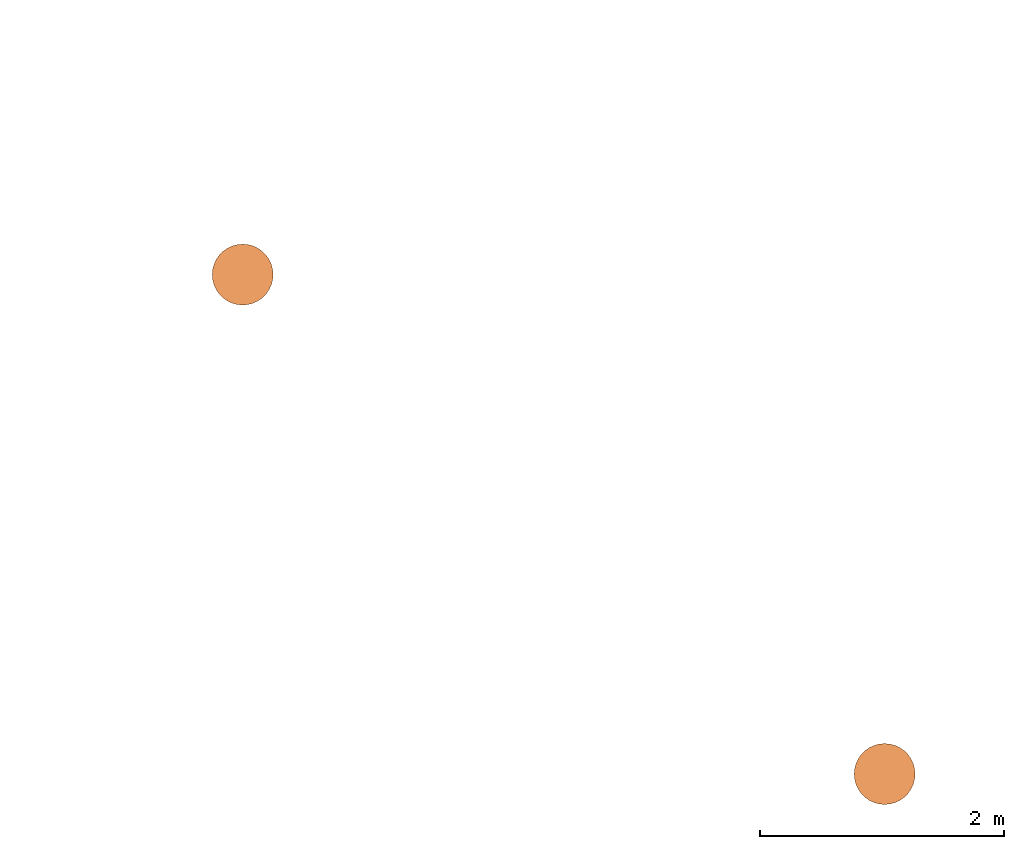
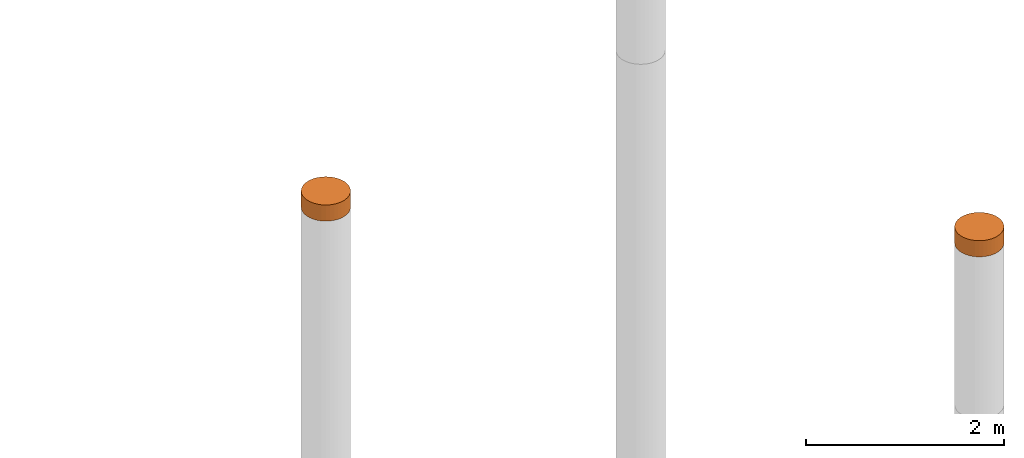
# One storey, part 7 of 8: 2 proxies.
"""IFC4 building model written with IfcOpenShell, lengths in metres."""

import ifcopenshell
import ifcopenshell.guid

model = None  # the IFC model being written
_history = None  # IfcOwnerHistory: only IFC2X3 demands one
_inside = {}  # id of a spatial element -> (the spatial element, [elements in it])
_under = {}  # id of a project, library or spatial element -> (it, [spatial elements below it])
_declared = {}  # id of a project -> (the project, [libraries it declares])
_typed = {}  # id of a type object -> (the type object, [elements of that type])
_made_of = {}  # id of a material, layer set ... -> (it, [elements and type objects made of it])


def new_model(schema):
    """Start an empty IFC model of exactly this schema.

    Asked for "IFC4X3", IfcOpenShell would pick the latest addendum, in which some entities
    have other attributes; the version numbers below select the first issue.
    IFC2X3 requires an IfcOwnerHistory on every rooted entity: one is made here for all.
    """
    global model, _history
    if schema == "IFC4X3":
        model = ifcopenshell.file(schema_version=(4, 3, 0, 0))
    else:
        model = ifcopenshell.file(schema=schema)
    _inside.clear()
    _under.clear()
    _declared.clear()
    _typed.clear()
    _made_of.clear()
    _history = None
    if model.schema == "IFC2X3":
        org = make("IfcOrganization", Name="unknown")
        user = make(
            "IfcPersonAndOrganization",
            ThePerson=make("IfcPerson", FamilyName="unknown"),
            TheOrganization=org,
        )
        app = make(
            "IfcApplication",
            ApplicationDeveloper=org,
            Version="unknown",
            ApplicationFullName="unknown",
            ApplicationIdentifier="unknown",
        )
        _history = make(
            "IfcOwnerHistory",
            OwningUser=user,
            OwningApplication=app,
            ChangeAction="ADDED",
            CreationDate=0,
        )
    return model


def make(cls, **values):
    """One entity of the class cls with the attributes given. An attribute that is None is left unset."""
    return model.create_entity(
        cls, **{name: value for name, value in values.items() if value is not None}
    )


def entity(cls, *values):
    """Any entity or typed value of the class cls, its attributes in the order of the schema. None: left unset."""
    e = model.create_entity(cls)
    for i, value in enumerate(values):
        if value is not None:
            e[i] = value
    return e


def rooted(cls, **values):
    """An entity with a GlobalId (a new one), such as an element, a storey or a relation."""
    return make(cls, GlobalId=ifcopenshell.guid.new(), OwnerHistory=_history, **values)


def si_unit(unit_type, name, prefix=None):
    """IfcSIUnit, for example si_unit("LENGTHUNIT", "METRE", prefix="MILLI")."""
    return make("IfcSIUnit", UnitType=unit_type, Prefix=prefix, Name=name)


def converted_unit(unit_type, name, factor, base, dimensions=None, offset=None):
    """IfcConversionBasedUnit, such as the inch: factor (a typed value) times the base unit."""
    return make(
        "IfcConversionBasedUnit"
        if offset is None
        else "IfcConversionBasedUnitWithOffset",
        ConversionOffset=offset,
        Dimensions=None
        if dimensions is None
        else entity("IfcDimensionalExponents", *dimensions),
        UnitType=unit_type,
        Name=name,
        ConversionFactor=make(
            "IfcMeasureWithUnit", ValueComponent=factor, UnitComponent=base
        ),
    )


def assignment(units):
    """IfcUnitAssignment: the units of a project."""
    return None if units is None else make("IfcUnitAssignment", Units=units)


def point(xyz):
    """IfcCartesianPoint."""
    return None if xyz is None else make("IfcCartesianPoint", Coordinates=xyz)


def direction(xyz):
    """IfcDirection."""
    return None if xyz is None else make("IfcDirection", DirectionRatios=xyz)


def frame(location, z_axis=None, x_axis=None):
    """IfcAxis2Placement3D, a coordinate frame: its origin and axes. An axis left out is left unset."""
    return make(
        "IfcAxis2Placement3D",
        Location=point(location),
        Axis=direction(z_axis),
        RefDirection=direction(x_axis),
    )


def origin():
    """The frame at (0, 0, 0) with its axes left unset."""
    return frame((0.0, 0.0, 0.0))


def place(relative_to, where):
    """IfcLocalPlacement: puts the frame where relative to a parent placement (None: the world)."""
    return make(
        "IfcLocalPlacement", PlacementRelTo=relative_to, RelativePlacement=where
    )


def context(
    kind, dimensions, precision=None, world=None, true_north=None, identifier=None
):
    """IfcGeometricRepresentationContext, for example the 3D "Model" context."""
    return make(
        "IfcGeometricRepresentationContext",
        ContextIdentifier=identifier,
        ContextType=kind,
        CoordinateSpaceDimension=dimensions,
        Precision=precision,
        WorldCoordinateSystem=world,
        TrueNorth=true_north,
    )


def subcontext(parent, identifier, kind, view, scale=None):
    """IfcGeometricRepresentationSubContext, for example "Body" below "Model"."""
    return make(
        "IfcGeometricRepresentationSubContext",
        ContextIdentifier=identifier,
        ContextType=kind,
        ParentContext=parent,
        TargetScale=scale,
        TargetView=view,
    )


def project(units=None, contexts=None):
    """IfcProject with its units and contexts."""
    return rooted(
        "IfcProject",
        Name="project",
        RepresentationContexts=contexts,
        UnitsInContext=assignment(units),
    )


def spatial(cls, under=None, at=None, **own):
    """A site, building, storey or space (cls), placed at a placement, below another one or the project."""
    s = rooted(cls, ObjectPlacement=at, **own)
    if under is not None:
        _under.setdefault(under.id(), (under, []))[1].append(s)
    return s


def faces_of(points, faces, orient=None, outer=None):
    """IfcFace entities. A face is a list of loops; a loop is a list of indices into points, from 0.

    orient and outer hold one flag for each loop. By default every Orientation is true, the
    first loop of a face is its IfcFaceOuterBound and the others are IfcFaceBound.
    """
    made = []
    for i, loops in enumerate(faces):
        bounds = []
        for j, loop in enumerate(loops):
            is_outer = j == 0 if outer is None else outer[i][j]
            bounds.append(
                make(
                    "IfcFaceOuterBound" if is_outer else "IfcFaceBound",
                    Bound=make("IfcPolyLoop", Polygon=[points[k] for k in loop]),
                    Orientation=True if orient is None else orient[i][j],
                )
            )
        made.append(make("IfcFace", Bounds=bounds))
    return made


def faceted_brep(points, faces, orient=None, outer=None, voids=None):
    """IfcFacetedBrep: a solid bounded by flat faces; with voids (closed shells), ...WithVoids."""
    shared = [point(p) for p in points]
    hull = make("IfcClosedShell", CfsFaces=faces_of(shared, faces, orient, outer))
    if voids is None:
        return make("IfcFacetedBrep", Outer=hull)
    return make(
        "IfcFacetedBrepWithVoids",
        Outer=hull,
        Voids=[
            make(cls, CfsFaces=faces_of(shared, fs, o, b)) for cls, fs, o, b in voids
        ],
    )


def shape(context_of_items, identifier, shape_type, items):
    """IfcShapeRepresentation: the items that make up one representation, for example the "Body"."""
    return make(
        "IfcShapeRepresentation",
        ContextOfItems=context_of_items,
        RepresentationIdentifier=identifier,
        RepresentationType=shape_type,
        Items=items,
    )


def material(Name=None, Category=None):
    """IfcMaterial."""
    return make("IfcMaterial", Name=Name, Category=Category)


def made_of(thing, what):
    """Note that an element or type object is made of a material, layer set ...; save() writes the relation."""
    if what is not None:
        _made_of.setdefault(what.id(), (what, []))[1].append(thing)
    return thing


def element(
    cls,
    number,
    at=None,
    inside=None,
    cuts=None,
    type_object=None,
    material=None,
    context=None,
    identifier="Body",
    shape_type=None,
    held_by="IfcProductDefinitionShape",
    body=None,
    shapes=None,
    **own,
):
    """One element of the class cls, such as IfcWall. Its Tag is "e" and its number.

    at: its placement. inside: the storey or other place that contains it. cuts: it is an
    opening in that element (IfcRelVoidsElement). A single representation is given by context,
    identifier, shape_type and body (its items); several are given by shapes. held_by: the class
    of the entity that holds the representations. save() writes the other relations.
    """
    e = rooted(cls, Tag="e%d" % number, ObjectPlacement=at, **own)
    if body is not None:
        shapes = [shape(context, identifier, shape_type, body)]
    if shapes is not None:
        e.Representation = make(held_by, Representations=shapes)
    if inside is not None:
        _inside.setdefault(inside.id(), (inside, []))[1].append(e)
    if cuts is not None:
        rooted(
            "IfcRelVoidsElement", RelatingBuildingElement=cuts, RelatedOpeningElement=e
        )
    if type_object is not None:
        _typed.setdefault(type_object.id(), (type_object, []))[1].append(e)
    return made_of(e, material)


def aggregate(whole, parts):
    """IfcRelAggregates: a whole, such as a stair, and the parts it consists of."""
    return rooted("IfcRelAggregates", RelatingObject=whole, RelatedObjects=parts)


def save(model, path):
    """Write the relations noted so far, then the file.

    IfcRelAggregates (storeys below a building ...), IfcRelContainedInSpatialStructure (elements
    in a storey), IfcRelDefinesByType, IfcRelAssociatesMaterial and IfcRelDeclares: one each for
    every whole, place, type object, material and project.
    """
    for whole, parts in _under.values():
        aggregate(whole, parts)
    for where, things in _inside.values():
        rooted(
            "IfcRelContainedInSpatialStructure",
            RelatedElements=things,
            RelatingStructure=where,
        )
    for kind, things in _typed.values():
        rooted("IfcRelDefinesByType", RelatedObjects=things, RelatingType=kind)
    for what, things in _made_of.values():
        rooted("IfcRelAssociatesMaterial", RelatedObjects=things, RelatingMaterial=what)
    for by, libraries in _declared.values():
        rooted("IfcRelDeclares", RelatingContext=by, RelatedDefinitions=libraries)
    model.write(path)


model = new_model("IFC4")

# Units and contexts
model_context = context("Model", 3, precision=1e-05, world=origin())
body_context = subcontext(model_context, "Body", "Model", "MODEL_VIEW")
ifc_project = project(units=[si_unit("LENGTHUNIT", "METRE"), si_unit("AREAUNIT", "SQUARE_METRE"), si_unit("VOLUMEUNIT", "CUBIC_METRE"), converted_unit("PLANEANGLEUNIT", "DEGREE", entity("IfcPlaneAngleMeasure", 0.0174532925199433), si_unit("PLANEANGLEUNIT", "RADIAN"), dimensions=[0, 0, 0, 0, 0, 0, 0])], contexts=[model_context])

# Site, building, storey
site_placement = place(None, origin())
site = spatial("IfcSite", under=ifc_project, at=site_placement, CompositionType="ELEMENT")
building_placement = place(site_placement, origin())
building = spatial("IfcBuilding", under=site, at=building_placement, Name="Demo", CompositionType="ELEMENT")
storey_placement = place(building_placement, origin())
storey = spatial("IfcBuildingStorey", under=building, at=storey_placement, Name="Boden", CompositionType="ELEMENT", Elevation=0.0)

# Proxies
ifc_material_1 = material()
proxy_1_placement = place(storey_placement, frame((15.17, 5.39, -5.115699530655604e-18)))
element("IfcBuildingElementProxy", 1, at=proxy_1_placement, inside=storey, material=ifc_material_1, Name="KB-02", PredefinedType="USERDEFINED", context=body_context, shape_type="Brep", body=[
    faceted_brep([(0.4962019382530525, 0.2934120444167338, 0.2), (0.5, 0.25, 0.2), (0.4962019382530525, 0.2065879555832671, 0.2), (0.4849231551964767, 0.1644949641685826, 0.2), (0.4665063509461107, 0.125, 0.2), (0.4415111107797439, 0.08930309757836494, 0.2), (0.4106969024216342, 0.05848888922025526, 0.2), (0.375, 0.0334936490538903, 0.2), (0.3355050358314166, 0.01507684480352327, 0.2), (0.2934120444167329, 0.003798061746948406, 0.2), (0.25, 0.0, 0.2), (0.2065879555832671, 0.003798061746948406, 0.2), (0.1644949641685835, 0.01507684480352327, 0.2), (0.125, 0.0334936490538903, 0.2), (0.08930309757836585, 0.05848888922025526, 0.2), (0.05848888922025617, 0.08930309757836494, 0.2), (0.0334936490538912, 0.125, 0.2), (0.01507684480352327, 0.1644949641685826, 0.2), (0.003798061746947497, 0.2065879555832671, 0.2), (0.0, 0.25, 0.2), (0.003798061746947497, 0.293412044416732, 0.2), (0.01507684480352327, 0.3355050358314166, 0.2), (0.03349364905388939, 0.375, 0.2), (0.05848888922025435, 0.4106969024216342, 0.2), (0.08930309757836404, 0.4415111107797439, 0.2), (0.125, 0.4665063509461097, 0.2), (0.1644949641685816, 0.4849231551964767, 0.2), (0.2065879555832671, 0.4962019382530516, 0.2), (0.25, 0.5, 0.2), (0.2934120444167311, 0.4962019382530525, 0.2), (0.3355050358314166, 0.4849231551964777, 0.2), (0.375, 0.4665063509461097, 0.2), (0.4106969024216342, 0.4415111107797448, 0.2), (0.4415111107797439, 0.410696902421636, 0.2), (0.4665063509461088, 0.3750000000000009, 0.2), (0.4849231551964767, 0.3355050358314184, 0.2), (0.5, 0.25, 5.115699530655604e-18), (0.4962019382530525, 0.2934120444167338, 5.115699530655604e-18), (0.4849231551964767, 0.3355050358314184, 5.115699530655604e-18), (0.4665063509461088, 0.3750000000000009, 5.115699530655604e-18), (0.4415111107797439, 0.410696902421636, 5.115699530655604e-18), (0.4106969024216342, 0.4415111107797448, 5.115699530655604e-18), (0.375, 0.4665063509461097, 5.115699530655604e-18), (0.3355050358314166, 0.4849231551964777, 5.115699530655604e-18), (0.2934120444167311, 0.4962019382530525, 5.115699530655604e-18), (0.25, 0.5, 5.115699530655604e-18), (0.2065879555832671, 0.4962019382530516, 5.115699530655604e-18), (0.1644949641685816, 0.4849231551964767, 5.115699530655604e-18), (0.125, 0.4665063509461097, 5.115699530655604e-18), (0.08930309757836404, 0.4415111107797439, 5.115699530655604e-18), (0.05848888922025435, 0.4106969024216342, 5.115699530655604e-18), (0.03349364905388939, 0.3749999999999991, 5.115699530655604e-18), (0.01507684480352327, 0.3355050358314166, 5.115699530655604e-18), (0.003798061746947497, 0.293412044416732, 5.115699530655604e-18), (0.0, 0.25, 5.115699530655604e-18), (0.003798061746947497, 0.2065879555832671, 5.115699530655604e-18), (0.01507684480352327, 0.1644949641685826, 5.115699530655604e-18), (0.0334936490538912, 0.125, 5.115699530655604e-18), (0.05848888922025617, 0.08930309757836494, 5.115699530655604e-18), (0.08930309757836585, 0.05848888922025526, 5.115699530655604e-18), (0.125, 0.0334936490538903, 5.115699530655604e-18), (0.1644949641685835, 0.01507684480352327, 5.115699530655604e-18), (0.2065879555832671, 0.003798061746948406, 5.115699530655604e-18), (0.25, 0.0, 5.115699530655604e-18), (0.2934120444167329, 0.003798061746948406, 5.115699530655604e-18), (0.3355050358314166, 0.01507684480352327, 5.115699530655604e-18), (0.375, 0.0334936490538903, 5.115699530655604e-18), (0.4106969024216342, 0.05848888922025526, 5.115699530655604e-18), (0.4415111107797439, 0.08930309757836494, 5.115699530655604e-18), (0.4665063509461107, 0.125, 5.115699530655604e-18), (0.4849231551964767, 0.1644949641685826, 5.115699530655604e-18), (0.4962019382530525, 0.2065879555832671, 5.115699530655604e-18), (0.5, 0.25, 0.2), (0.4962019382530525, 0.2934120444167338, 0.2), (0.4962019382530525, 0.2934120444167338, 5.115699530655604e-18), (0.5, 0.25, 5.115699530655604e-18), (0.4962019382530525, 0.2065879555832671, 0.2), (0.5, 0.25, 0.2), (0.5, 0.25, 5.115699530655604e-18), (0.4962019382530525, 0.2065879555832671, 5.115699530655604e-18), (0.4849231551964767, 0.1644949641685826, 0.2), (0.4962019382530525, 0.2065879555832671, 0.2), (0.4962019382530525, 0.2065879555832671, 5.115699530655604e-18), (0.4849231551964767, 0.1644949641685826, 5.115699530655604e-18), (0.4665063509461107, 0.125, 0.2), (0.4849231551964767, 0.1644949641685826, 0.2), (0.4849231551964767, 0.1644949641685826, 5.115699530655604e-18), (0.4665063509461107, 0.125, 5.115699530655604e-18), (0.4415111107797439, 0.08930309757836494, 0.2), (0.4665063509461107, 0.125, 0.2), (0.4665063509461107, 0.125, 5.115699530655604e-18), (0.4415111107797439, 0.08930309757836494, 5.115699530655604e-18), (0.4106969024216342, 0.05848888922025526, 0.2), (0.4415111107797439, 0.08930309757836494, 0.2), (0.4415111107797439, 0.08930309757836494, 5.115699530655604e-18), (0.4106969024216342, 0.05848888922025526, 5.115699530655604e-18), (0.375, 0.0334936490538903, 0.2), (0.4106969024216342, 0.05848888922025526, 0.2), (0.4106969024216342, 0.05848888922025526, 5.115699530655604e-18), (0.375, 0.0334936490538903, 5.115699530655604e-18), (0.3355050358314166, 0.01507684480352327, 0.2), (0.375, 0.0334936490538903, 0.2), (0.375, 0.0334936490538903, 5.115699530655604e-18), (0.3355050358314166, 0.01507684480352327, 5.115699530655604e-18), (0.2934120444167329, 0.003798061746948406, 0.2), (0.3355050358314166, 0.01507684480352327, 0.2), (0.3355050358314166, 0.01507684480352327, 5.115699530655604e-18), (0.2934120444167329, 0.003798061746948406, 5.115699530655604e-18), (0.25, 0.0, 0.2), (0.2934120444167329, 0.003798061746948406, 0.2), (0.2934120444167329, 0.003798061746948406, 5.115699530655604e-18), (0.25, 0.0, 5.115699530655604e-18), (0.2065879555832671, 0.003798061746948406, 0.2), (0.25, 0.0, 0.2), (0.25, 0.0, 5.115699530655604e-18), (0.2065879555832671, 0.003798061746948406, 5.115699530655604e-18), (0.1644949641685835, 0.01507684480352327, 0.2), (0.2065879555832671, 0.003798061746948406, 0.2), (0.2065879555832671, 0.003798061746948406, 5.115699530655604e-18), (0.1644949641685835, 0.01507684480352327, 5.115699530655604e-18), (0.125, 0.0334936490538903, 0.2), (0.1644949641685835, 0.01507684480352327, 0.2), (0.1644949641685835, 0.01507684480352327, 5.115699530655604e-18), (0.125, 0.0334936490538903, 5.115699530655604e-18), (0.08930309757836585, 0.05848888922025526, 0.2), (0.125, 0.0334936490538903, 0.2), (0.125, 0.0334936490538903, 5.115699530655604e-18), (0.08930309757836585, 0.05848888922025526, 5.115699530655604e-18), (0.05848888922025617, 0.08930309757836494, 0.2), (0.08930309757836585, 0.05848888922025526, 0.2), (0.08930309757836585, 0.05848888922025526, 5.115699530655604e-18), (0.05848888922025617, 0.08930309757836494, 5.115699530655604e-18), (0.0334936490538912, 0.125, 0.2), (0.05848888922025617, 0.08930309757836494, 0.2), (0.05848888922025617, 0.08930309757836494, 5.115699530655604e-18), (0.0334936490538912, 0.125, 5.115699530655604e-18), (0.01507684480352327, 0.1644949641685826, 0.2), (0.0334936490538912, 0.125, 0.2), (0.0334936490538912, 0.125, 5.115699530655604e-18), (0.01507684480352327, 0.1644949641685826, 5.115699530655604e-18), (0.003798061746947497, 0.2065879555832671, 0.2), (0.01507684480352327, 0.1644949641685826, 0.2), (0.01507684480352327, 0.1644949641685826, 5.115699530655604e-18), (0.003798061746947497, 0.2065879555832671, 5.115699530655604e-18), (0.0, 0.25, 0.2), (0.003798061746947497, 0.2065879555832671, 0.2), (0.003798061746947497, 0.2065879555832671, 5.115699530655604e-18), (0.0, 0.25, 5.115699530655604e-18), (0.003798061746947497, 0.293412044416732, 0.2), (0.0, 0.25, 0.2), (0.0, 0.25, 5.115699530655604e-18), (0.003798061746947497, 0.293412044416732, 5.115699530655604e-18), (0.01507684480352327, 0.3355050358314166, 0.2), (0.003798061746947497, 0.293412044416732, 0.2), (0.003798061746947497, 0.293412044416732, 5.115699530655604e-18), (0.01507684480352327, 0.3355050358314166, 5.115699530655604e-18), (0.03349364905388939, 0.375, 0.2), (0.01507684480352327, 0.3355050358314166, 0.2), (0.01507684480352327, 0.3355050358314166, 5.115699530655604e-18), (0.03349364905388939, 0.3749999999999991, 5.115699530655604e-18), (0.05848888922025435, 0.4106969024216342, 0.2), (0.03349364905388939, 0.375, 0.2), (0.03349364905388939, 0.3749999999999991, 5.115699530655604e-18), (0.05848888922025435, 0.4106969024216342, 5.115699530655604e-18), (0.08930309757836404, 0.4415111107797439, 0.2), (0.05848888922025435, 0.4106969024216342, 0.2), (0.05848888922025435, 0.4106969024216342, 5.115699530655604e-18), (0.08930309757836404, 0.4415111107797439, 5.115699530655604e-18), (0.125, 0.4665063509461097, 0.2), (0.08930309757836404, 0.4415111107797439, 0.2), (0.08930309757836404, 0.4415111107797439, 5.115699530655604e-18), (0.125, 0.4665063509461097, 5.115699530655604e-18), (0.1644949641685816, 0.4849231551964767, 0.2), (0.125, 0.4665063509461097, 0.2), (0.125, 0.4665063509461097, 5.115699530655604e-18), (0.1644949641685816, 0.4849231551964767, 5.115699530655604e-18), (0.2065879555832671, 0.4962019382530516, 0.2), (0.1644949641685816, 0.4849231551964767, 0.2), (0.1644949641685816, 0.4849231551964767, 5.115699530655604e-18), (0.2065879555832671, 0.4962019382530516, 5.115699530655604e-18), (0.25, 0.5, 0.2), (0.2065879555832671, 0.4962019382530516, 0.2), (0.2065879555832671, 0.4962019382530516, 5.115699530655604e-18), (0.25, 0.5, 5.115699530655604e-18), (0.2934120444167311, 0.4962019382530525, 0.2), (0.25, 0.5, 0.2), (0.25, 0.5, 5.115699530655604e-18), (0.2934120444167311, 0.4962019382530525, 5.115699530655604e-18), (0.3355050358314166, 0.4849231551964777, 0.2), (0.2934120444167311, 0.4962019382530525, 0.2), (0.2934120444167311, 0.4962019382530525, 5.115699530655604e-18), (0.3355050358314166, 0.4849231551964777, 5.115699530655604e-18), (0.375, 0.4665063509461097, 0.2), (0.3355050358314166, 0.4849231551964777, 0.2), (0.3355050358314166, 0.4849231551964777, 5.115699530655604e-18), (0.375, 0.4665063509461097, 5.115699530655604e-18), (0.4106969024216342, 0.4415111107797448, 0.2), (0.375, 0.4665063509461097, 0.2), (0.375, 0.4665063509461097, 5.115699530655604e-18), (0.4106969024216342, 0.4415111107797448, 5.115699530655604e-18), (0.4415111107797439, 0.410696902421636, 0.2), (0.4106969024216342, 0.4415111107797448, 0.2), (0.4106969024216342, 0.4415111107797448, 5.115699530655604e-18), (0.4415111107797439, 0.410696902421636, 5.115699530655604e-18), (0.4665063509461088, 0.3750000000000009, 0.2), (0.4415111107797439, 0.410696902421636, 0.2), (0.4415111107797439, 0.410696902421636, 5.115699530655604e-18), (0.4665063509461088, 0.3750000000000009, 5.115699530655604e-18), (0.4849231551964767, 0.3355050358314184, 0.2), (0.4665063509461088, 0.3750000000000009, 0.2), (0.4665063509461088, 0.3750000000000009, 5.115699530655604e-18), (0.4849231551964767, 0.3355050358314184, 5.115699530655604e-18), (0.4962019382530525, 0.2934120444167338, 0.2), (0.4849231551964767, 0.3355050358314184, 0.2), (0.4849231551964767, 0.3355050358314184, 5.115699530655604e-18), (0.4962019382530525, 0.2934120444167338, 5.115699530655604e-18)], [[[0, 1, 2, 3, 4, 5, 6, 7, 8, 9, 10, 11, 12, 13, 14, 15, 16, 17, 18, 19, 20, 21, 22, 23, 24, 25, 26, 27, 28, 29, 30, 31, 32, 33, 34, 35]], [[36, 37, 38, 39, 40, 41, 42, 43, 44, 45, 46, 47, 48, 49, 50, 51, 52, 53, 54, 55, 56, 57, 58, 59, 60, 61, 62, 63, 64, 65, 66, 67, 68, 69, 70, 71]], [[72, 73, 74, 75]], [[76, 77, 78, 79]], [[80, 81, 82, 83]], [[84, 85, 86, 87]], [[88, 89, 90, 91]], [[92, 93, 94, 95]], [[96, 97, 98, 99]], [[100, 101, 102, 103]], [[104, 105, 106, 107]], [[108, 109, 110, 111]], [[112, 113, 114, 115]], [[116, 117, 118, 119]], [[120, 121, 122, 123]], [[124, 125, 126, 127]], [[128, 129, 130, 131]], [[132, 133, 134, 135]], [[136, 137, 138, 139]], [[140, 141, 142, 143]], [[144, 145, 146, 147]], [[148, 149, 150, 151]], [[152, 153, 154, 155]], [[156, 157, 158, 159]], [[160, 161, 162, 163]], [[164, 165, 166, 167]], [[168, 169, 170, 171]], [[172, 173, 174, 175]], [[176, 177, 178, 179]], [[180, 181, 182, 183]], [[184, 185, 186, 187]], [[188, 189, 190, 191]], [[192, 193, 194, 195]], [[196, 197, 198, 199]], [[200, 201, 202, 203]], [[204, 205, 206, 207]], [[208, 209, 210, 211]], [[212, 213, 214, 215]]], orient=[[False], [False], [False], [False], [False], [False], [False], [False], [False], [False], [False], [False], [False], [False], [False], [False], [False], [False], [False], [False], [False], [False], [False], [False], [False], [False], [False], [False], [False], [False], [False], [False], [False], [False], [False], [False], [False], [False]]),
])
ifc_material_2 = material()
proxy_2_placement = place(storey_placement, frame((9.9, 9.49, -0.2)))
element("IfcBuildingElementProxy", 2, at=proxy_2_placement, inside=storey, material=ifc_material_2, Name="KB-05", PredefinedType="USERDEFINED", context=body_context, shape_type="Brep", body=[
    faceted_brep([(0.4962019382530525, 0.2934120444167329, 0.2), (0.5, 0.25, 0.2), (0.4962019382530525, 0.2065879555832671, 0.2), (0.4849231551964767, 0.1644949641685835, 0.2), (0.4665063509461107, 0.125, 0.2), (0.4415111107797439, 0.08930309757836585, 0.2), (0.4106969024216342, 0.05848888922025617, 0.2), (0.375, 0.0334936490538912, 0.2), (0.3355050358314166, 0.01507684480352327, 0.2), (0.2934120444167329, 0.003798061746947497, 0.2), (0.25, 0.0, 0.2), (0.2065879555832671, 0.003798061746947497, 0.2), (0.1644949641685835, 0.01507684480352327, 0.2), (0.125, 0.03349364905388939, 0.2), (0.08930309757836585, 0.05848888922025617, 0.2), (0.05848888922025617, 0.08930309757836585, 0.2), (0.0334936490538912, 0.125, 0.2), (0.01507684480352327, 0.1644949641685835, 0.2), (0.003798061746947497, 0.2065879555832671, 0.2), (0.0, 0.25, 0.2), (0.003798061746947497, 0.2934120444167329, 0.2), (0.01507684480352327, 0.3355050358314166, 0.2), (0.03349364905388939, 0.375, 0.2), (0.05848888922025435, 0.4106969024216342, 0.2), (0.08930309757836404, 0.4415111107797439, 0.2), (0.125, 0.4665063509461088, 0.2), (0.1644949641685816, 0.4849231551964767, 0.2), (0.2065879555832671, 0.4962019382530525, 0.2), (0.25, 0.5, 0.2), (0.2934120444167311, 0.4962019382530525, 0.2), (0.3355050358314166, 0.4849231551964767, 0.2), (0.375, 0.4665063509461107, 0.2), (0.4106969024216342, 0.4415111107797456, 0.2), (0.4415111107797439, 0.410696902421636, 0.2), (0.4665063509461088, 0.375, 0.2), (0.4849231551964767, 0.3355050358314184, 0.2), (0.5, 0.25, 0.0), (0.4962019382530525, 0.2934120444167329, 0.0), (0.4849231551964767, 0.3355050358314184, 0.0), (0.4665063509461088, 0.375, 0.0), (0.4415111107797439, 0.410696902421636, 0.0), (0.4106969024216342, 0.4415111107797456, 0.0), (0.375, 0.4665063509461107, 0.0), (0.3355050358314166, 0.4849231551964767, 0.0), (0.2934120444167311, 0.4962019382530525, 0.0), (0.25, 0.5, 0.0), (0.2065879555832671, 0.4962019382530525, 0.0), (0.1644949641685816, 0.4849231551964767, 0.0), (0.125, 0.4665063509461088, 0.0), (0.08930309757836404, 0.4415111107797439, 0.0), (0.05848888922025435, 0.4106969024216342, 0.0), (0.03349364905388939, 0.375, 0.0), (0.01507684480352327, 0.3355050358314166, 0.0), (0.003798061746947497, 0.2934120444167329, 0.0), (0.0, 0.25, 0.0), (0.003798061746947497, 0.2065879555832671, 0.0), (0.01507684480352327, 0.1644949641685816, 0.0), (0.0334936490538912, 0.125, 0.0), (0.05848888922025617, 0.08930309757836585, 0.0), (0.08930309757836585, 0.05848888922025617, 0.0), (0.125, 0.03349364905388939, 0.0), (0.1644949641685835, 0.01507684480352327, 0.0), (0.2065879555832671, 0.003798061746947497, 0.0), (0.25, 0.0, 0.0), (0.2934120444167329, 0.003798061746947497, 0.0), (0.3355050358314166, 0.01507684480352327, 0.0), (0.375, 0.0334936490538912, 0.0), (0.4106969024216342, 0.05848888922025617, 0.0), (0.4415111107797439, 0.08930309757836585, 0.0), (0.4665063509461107, 0.125, 0.0), (0.4849231551964767, 0.1644949641685835, 0.0), (0.4962019382530525, 0.2065879555832671, 0.0), (0.5, 0.25, 0.2), (0.4962019382530525, 0.2934120444167329, 0.2), (0.4962019382530525, 0.2934120444167329, 0.0), (0.5, 0.25, 0.0), (0.4962019382530525, 0.2065879555832671, 0.2), (0.5, 0.25, 0.2), (0.5, 0.25, 0.0), (0.4962019382530525, 0.2065879555832671, 0.0), (0.4849231551964767, 0.1644949641685835, 0.2), (0.4962019382530525, 0.2065879555832671, 0.2), (0.4962019382530525, 0.2065879555832671, 0.0), (0.4849231551964767, 0.1644949641685835, 0.0), (0.4665063509461107, 0.125, 0.2), (0.4849231551964767, 0.1644949641685835, 0.2), (0.4849231551964767, 0.1644949641685835, 0.0), (0.4665063509461107, 0.125, 0.0), (0.4415111107797439, 0.08930309757836585, 0.2), (0.4665063509461107, 0.125, 0.2), (0.4665063509461107, 0.125, 0.0), (0.4415111107797439, 0.08930309757836585, 0.0), (0.4106969024216342, 0.05848888922025617, 0.2), (0.4415111107797439, 0.08930309757836585, 0.2), (0.4415111107797439, 0.08930309757836585, 0.0), (0.4106969024216342, 0.05848888922025617, 0.0), (0.375, 0.0334936490538912, 0.2), (0.4106969024216342, 0.05848888922025617, 0.2), (0.4106969024216342, 0.05848888922025617, 0.0), (0.375, 0.0334936490538912, 0.0), (0.3355050358314166, 0.01507684480352327, 0.2), (0.375, 0.0334936490538912, 0.2), (0.375, 0.0334936490538912, 0.0), (0.3355050358314166, 0.01507684480352327, 0.0), (0.2934120444167329, 0.003798061746947497, 0.2), (0.3355050358314166, 0.01507684480352327, 0.2), (0.3355050358314166, 0.01507684480352327, 0.0), (0.2934120444167329, 0.003798061746947497, 0.0), (0.25, 0.0, 0.2), (0.2934120444167329, 0.003798061746947497, 0.2), (0.2934120444167329, 0.003798061746947497, 0.0), (0.25, 0.0, 0.0), (0.2065879555832671, 0.003798061746947497, 0.2), (0.25, 0.0, 0.2), (0.25, 0.0, 0.0), (0.2065879555832671, 0.003798061746947497, 0.0), (0.1644949641685835, 0.01507684480352327, 0.2), (0.2065879555832671, 0.003798061746947497, 0.2), (0.2065879555832671, 0.003798061746947497, 0.0), (0.1644949641685835, 0.01507684480352327, 0.0), (0.125, 0.03349364905388939, 0.2), (0.1644949641685835, 0.01507684480352327, 0.2), (0.1644949641685835, 0.01507684480352327, 0.0), (0.125, 0.03349364905388939, 0.0), (0.08930309757836585, 0.05848888922025617, 0.2), (0.125, 0.03349364905388939, 0.2), (0.125, 0.03349364905388939, 0.0), (0.08930309757836585, 0.05848888922025617, 0.0), (0.05848888922025617, 0.08930309757836585, 0.2), (0.08930309757836585, 0.05848888922025617, 0.2), (0.08930309757836585, 0.05848888922025617, 0.0), (0.05848888922025617, 0.08930309757836585, 0.0), (0.0334936490538912, 0.125, 0.2), (0.05848888922025617, 0.08930309757836585, 0.2), (0.05848888922025617, 0.08930309757836585, 0.0), (0.0334936490538912, 0.125, 0.0), (0.01507684480352327, 0.1644949641685835, 0.2), (0.0334936490538912, 0.125, 0.2), (0.0334936490538912, 0.125, 0.0), (0.01507684480352327, 0.1644949641685816, 0.0), (0.003798061746947497, 0.2065879555832671, 0.2), (0.01507684480352327, 0.1644949641685835, 0.2), (0.01507684480352327, 0.1644949641685816, 0.0), (0.003798061746947497, 0.2065879555832671, 0.0), (0.0, 0.25, 0.2), (0.003798061746947497, 0.2065879555832671, 0.2), (0.003798061746947497, 0.2065879555832671, 0.0), (0.0, 0.25, 0.0), (0.003798061746947497, 0.2934120444167329, 0.2), (0.0, 0.25, 0.2), (0.0, 0.25, 0.0), (0.003798061746947497, 0.2934120444167329, 0.0), (0.01507684480352327, 0.3355050358314166, 0.2), (0.003798061746947497, 0.2934120444167329, 0.2), (0.003798061746947497, 0.2934120444167329, 0.0), (0.01507684480352327, 0.3355050358314166, 0.0), (0.03349364905388939, 0.375, 0.2), (0.01507684480352327, 0.3355050358314166, 0.2), (0.01507684480352327, 0.3355050358314166, 0.0), (0.03349364905388939, 0.375, 0.0), (0.05848888922025435, 0.4106969024216342, 0.2), (0.03349364905388939, 0.375, 0.2), (0.03349364905388939, 0.375, 0.0), (0.05848888922025435, 0.4106969024216342, 0.0), (0.08930309757836404, 0.4415111107797439, 0.2), (0.05848888922025435, 0.4106969024216342, 0.2), (0.05848888922025435, 0.4106969024216342, 0.0), (0.08930309757836404, 0.4415111107797439, 0.0), (0.125, 0.4665063509461088, 0.2), (0.08930309757836404, 0.4415111107797439, 0.2), (0.08930309757836404, 0.4415111107797439, 0.0), (0.125, 0.4665063509461088, 0.0), (0.1644949641685816, 0.4849231551964767, 0.2), (0.125, 0.4665063509461088, 0.2), (0.125, 0.4665063509461088, 0.0), (0.1644949641685816, 0.4849231551964767, 0.0), (0.2065879555832671, 0.4962019382530525, 0.2), (0.1644949641685816, 0.4849231551964767, 0.2), (0.1644949641685816, 0.4849231551964767, 0.0), (0.2065879555832671, 0.4962019382530525, 0.0), (0.25, 0.5, 0.2), (0.2065879555832671, 0.4962019382530525, 0.2), (0.2065879555832671, 0.4962019382530525, 0.0), (0.25, 0.5, 0.0), (0.2934120444167311, 0.4962019382530525, 0.2), (0.25, 0.5, 0.2), (0.25, 0.5, 0.0), (0.2934120444167311, 0.4962019382530525, 0.0), (0.3355050358314166, 0.4849231551964767, 0.2), (0.2934120444167311, 0.4962019382530525, 0.2), (0.2934120444167311, 0.4962019382530525, 0.0), (0.3355050358314166, 0.4849231551964767, 0.0), (0.375, 0.4665063509461107, 0.2), (0.3355050358314166, 0.4849231551964767, 0.2), (0.3355050358314166, 0.4849231551964767, 0.0), (0.375, 0.4665063509461107, 0.0), (0.4106969024216342, 0.4415111107797456, 0.2), (0.375, 0.4665063509461107, 0.2), (0.375, 0.4665063509461107, 0.0), (0.4106969024216342, 0.4415111107797456, 0.0), (0.4415111107797439, 0.410696902421636, 0.2), (0.4106969024216342, 0.4415111107797456, 0.2), (0.4106969024216342, 0.4415111107797456, 0.0), (0.4415111107797439, 0.410696902421636, 0.0), (0.4665063509461088, 0.375, 0.2), (0.4415111107797439, 0.410696902421636, 0.2), (0.4415111107797439, 0.410696902421636, 0.0), (0.4665063509461088, 0.375, 0.0), (0.4849231551964767, 0.3355050358314184, 0.2), (0.4665063509461088, 0.375, 0.2), (0.4665063509461088, 0.375, 0.0), (0.4849231551964767, 0.3355050358314184, 0.0), (0.4962019382530525, 0.2934120444167329, 0.2), (0.4849231551964767, 0.3355050358314184, 0.2), (0.4849231551964767, 0.3355050358314184, 0.0), (0.4962019382530525, 0.2934120444167329, 0.0)], [[[0, 1, 2, 3, 4, 5, 6, 7, 8, 9, 10, 11, 12, 13, 14, 15, 16, 17, 18, 19, 20, 21, 22, 23, 24, 25, 26, 27, 28, 29, 30, 31, 32, 33, 34, 35]], [[36, 37, 38, 39, 40, 41, 42, 43, 44, 45, 46, 47, 48, 49, 50, 51, 52, 53, 54, 55, 56, 57, 58, 59, 60, 61, 62, 63, 64, 65, 66, 67, 68, 69, 70, 71]], [[72, 73, 74, 75]], [[76, 77, 78, 79]], [[80, 81, 82, 83]], [[84, 85, 86, 87]], [[88, 89, 90, 91]], [[92, 93, 94, 95]], [[96, 97, 98, 99]], [[100, 101, 102, 103]], [[104, 105, 106, 107]], [[108, 109, 110, 111]], [[112, 113, 114, 115]], [[116, 117, 118, 119]], [[120, 121, 122, 123]], [[124, 125, 126, 127]], [[128, 129, 130, 131]], [[132, 133, 134, 135]], [[136, 137, 138, 139]], [[140, 141, 142, 143]], [[144, 145, 146, 147]], [[148, 149, 150, 151]], [[152, 153, 154, 155]], [[156, 157, 158, 159]], [[160, 161, 162, 163]], [[164, 165, 166, 167]], [[168, 169, 170, 171]], [[172, 173, 174, 175]], [[176, 177, 178, 179]], [[180, 181, 182, 183]], [[184, 185, 186, 187]], [[188, 189, 190, 191]], [[192, 193, 194, 195]], [[196, 197, 198, 199]], [[200, 201, 202, 203]], [[204, 205, 206, 207]], [[208, 209, 210, 211]], [[212, 213, 214, 215]]], orient=[[False], [False], [False], [False], [False], [False], [False], [False], [False], [False], [False], [False], [False], [False], [False], [False], [False], [False], [False], [False], [False], [False], [False], [False], [False], [False], [False], [False], [False], [False], [False], [False], [False], [False], [False], [False], [False], [False]]),
])

save(model, "model.ifc")
